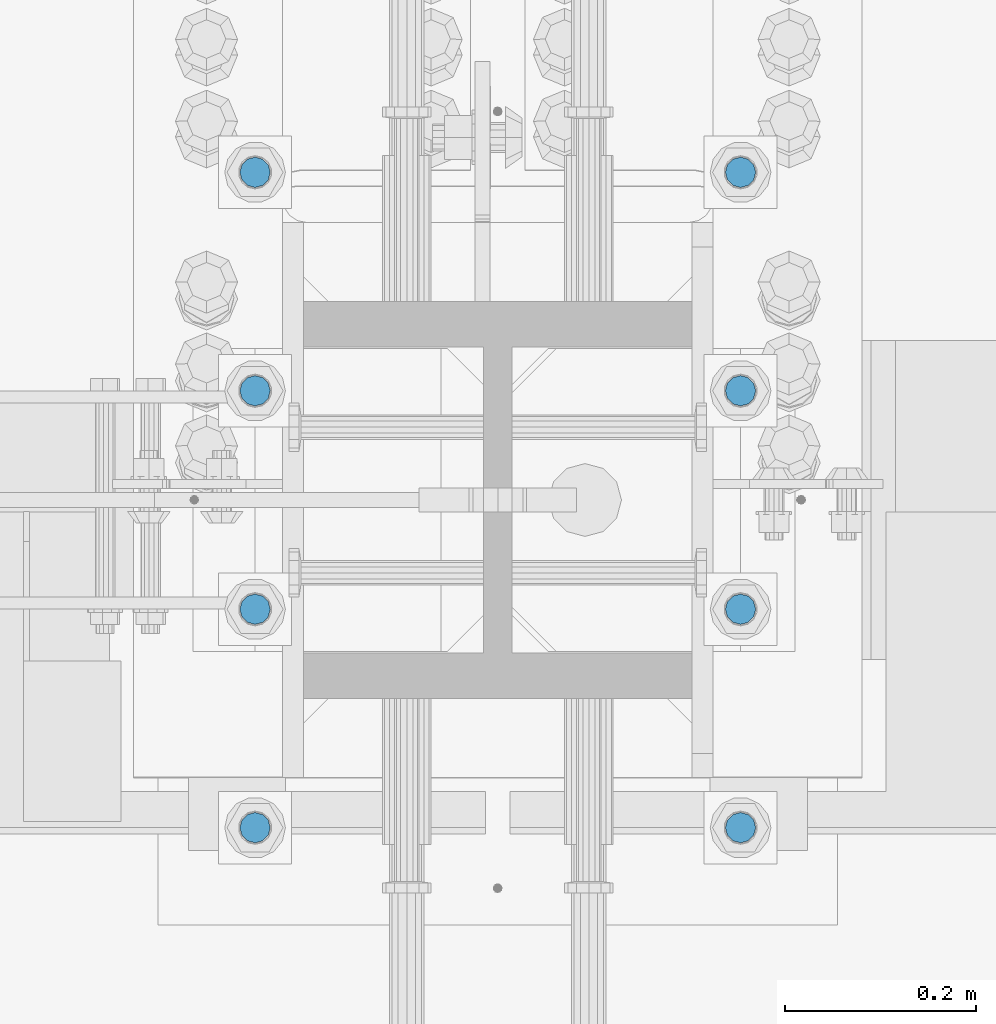
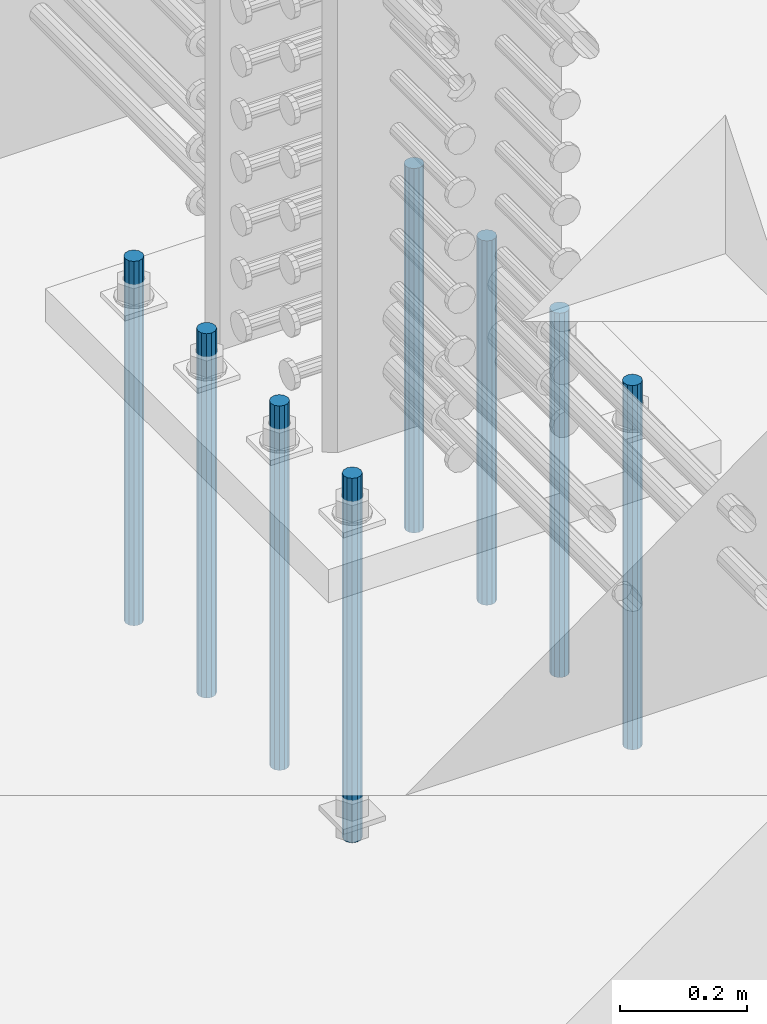
# One storey, part 937 of 1763: 8 columns, 1 element without a shape of its own.
"""IFC2X3 building model written with IfcOpenShell, lengths in millimetres."""

from ifc_helpers import new_model, si_unit, frame, origin_with_axes, place, context, subcontext, project, spatial, faceted_brep, material, type_object, element, aggregate, save


model = new_model("IFC2X3")

# Units and contexts
model_context = context("Model", 3, precision=1e-05, world=origin_with_axes())
body_context = subcontext(model_context, "Body", "Model", "MODEL_VIEW")
ifc_project = project(units=[si_unit("LENGTHUNIT", "METRE", prefix="MILLI"), si_unit("AREAUNIT", "SQUARE_METRE"), si_unit("VOLUMEUNIT", "CUBIC_METRE"), si_unit("MASSUNIT", "GRAM", prefix="KILO"), si_unit("TIMEUNIT", "SECOND"), si_unit("PLANEANGLEUNIT", "RADIAN"), si_unit("SOLIDANGLEUNIT", "STERADIAN"), si_unit("THERMODYNAMICTEMPERATUREUNIT", "DEGREE_CELSIUS"), si_unit("LUMINOUSINTENSITYUNIT", "LUMEN")], contexts=[model_context])

# Site, building, storey
site_placement = place(None, origin_with_axes())
site = spatial("IfcSite", under=ifc_project, at=site_placement, CompositionType="ELEMENT")
building_placement = place(site_placement, origin_with_axes())
building = spatial("IfcBuilding", under=site, at=building_placement, Name="Undefined", CompositionType="ELEMENT")
storey_placement = place(building_placement, origin_with_axes())
storey = spatial("IfcBuildingStorey", under=building, at=storey_placement, Name="Undefined", CompositionType="ELEMENT", Elevation=0.0)

# Assembly, columns
assembly_placement = place(storey_placement, origin_with_axes())
assembly = element("IfcElementAssembly", 1, at=assembly_placement, inside=storey, Name="TEMPLATE", AssemblyPlace="NOTDEFINED", PredefinedType="RIGID_FRAME")
ifc_material = material()
column_type = type_object("IfcColumnType", PredefinedType="NOTDEFINED")
column_1_placement = place(assembly_placement, frame((-24281.8372736984, -14058.9000000001, 4000.5), z_axis=(0.0, -1.0, 0.0), x_axis=(0.0, 0.0, -1.0)))
column_1 = element("IfcColumn", 2, at=column_1_placement, type_object=column_type, material=ifc_material, Name="ALL THREADED ROD", context=body_context, shape_type="Brep", body=[
    faceted_brep([(0.0, -15.875, 0.0), (0.0, -13.7481532850798, -7.9375), (698.499, -13.7481532850798, -7.9375), (698.499, -15.875, 0.0), (0.0, -7.9375, -13.748153285078), (698.499, -7.9375, -13.748153285078), (4.91792532185561e-12, 0.0, -15.875), (698.499, 0.0, -15.875), (0.0, 7.9375, -13.748153285078), (698.499, 7.9375, -13.748153285078), (0.0, 13.7481532850798, -7.9375), (698.499, 13.7481532850798, -7.9375), (0.0, 15.875, 0.0), (698.499, 15.875, 0.0), (0.0, 13.7481532850798, 7.9375), (698.499, 13.7481532850798, 7.9375), (0.0, 7.9375, 13.748153285078), (698.499, 7.9375, 13.748153285078), (-1.64518337079051e-12, 0.0, 15.875), (698.499, 0.0, 15.875), (0.0, -7.9375, 13.748153285078), (698.499, -7.9375, 13.748153285078), (0.0, -13.7481532850798, 7.9375), (698.499, -13.7481532850798, 7.9375)], [[[0, 1, 2, 3]], [[1, 4, 5, 2]], [[4, 6, 7, 5]], [[6, 8, 9, 7]], [[8, 10, 11, 9]], [[10, 12, 13, 11]], [[12, 14, 15, 13]], [[14, 16, 17, 15]], [[16, 18, 19, 17]], [[18, 20, 21, 19]], [[20, 22, 23, 21]], [[22, 0, 3, 23]], [[5, 7, 9, 11, 13, 15, 17, 19, 21, 23, 3, 2]], [[22, 20, 18, 16, 14, 12, 10, 8, 6, 4, 1, 0]]]),
])
column_2_placement = place(assembly_placement, frame((-23773.8372736984, -14058.9000000001, 4000.5), z_axis=(0.0, 1.0, 0.0), x_axis=(0.0, 0.0, -1.0)))
column_2 = element("IfcColumn", 3, at=column_2_placement, type_object=column_type, material=ifc_material, Name="ALL THREADED ROD", context=body_context, shape_type="Brep", body=[
    faceted_brep([(0.0, -15.875, 0.0), (0.0, -13.7481532850798, -7.9375), (698.499, -13.7481532850798, -7.9375), (698.499, -15.875, 0.0), (0.0, -7.9375, -13.748153285078), (698.499, -7.9375, -13.748153285078), (4.91792532185561e-12, 0.0, -15.875), (698.499, 0.0, -15.875), (0.0, 7.9375, -13.748153285078), (698.499, 7.9375, -13.748153285078), (0.0, 13.7481532850798, -7.9375), (698.499, 13.7481532850798, -7.9375), (0.0, 15.875, 0.0), (698.499, 15.875, 0.0), (0.0, 13.7481532850798, 7.9375), (698.499, 13.7481532850798, 7.9375), (0.0, 7.9375, 13.748153285078), (698.499, 7.9375, 13.748153285078), (-1.64518337079051e-12, 0.0, 15.875), (698.499, 0.0, 15.875), (0.0, -7.9375, 13.748153285078), (698.499, -7.9375, 13.748153285078), (0.0, -13.7481532850798, 7.9375), (698.499, -13.7481532850798, 7.9375)], [[[0, 1, 2, 3]], [[1, 4, 5, 2]], [[4, 6, 7, 5]], [[6, 8, 9, 7]], [[8, 10, 11, 9]], [[10, 12, 13, 11]], [[12, 14, 15, 13]], [[14, 16, 17, 15]], [[16, 18, 19, 17]], [[18, 20, 21, 19]], [[20, 22, 23, 21]], [[22, 0, 3, 23]], [[5, 7, 9, 11, 13, 15, 17, 19, 21, 23, 3, 2]], [[22, 20, 18, 16, 14, 12, 10, 8, 6, 4, 1, 0]]]),
])
column_3_placement = place(assembly_placement, frame((-24281.8372736984, -13830.3000000001, 4000.5), z_axis=(0.0, -1.0, 0.0), x_axis=(0.0, 0.0, -1.0)))
column_3 = element("IfcColumn", 4, at=column_3_placement, type_object=column_type, material=ifc_material, Name="ALL THREADED ROD", context=body_context, shape_type="Brep", body=[
    faceted_brep([(0.0, -15.875, 0.0), (0.0, -13.7481532850798, -7.9375), (698.499, -13.7481532850798, -7.9375), (698.499, -15.875, 0.0), (0.0, -7.9375, -13.748153285078), (698.499, -7.9375, -13.748153285078), (4.91792532185561e-12, 0.0, -15.875), (698.499, 0.0, -15.875), (0.0, 7.9375, -13.748153285078), (698.499, 7.9375, -13.748153285078), (0.0, 13.7481532850798, -7.9375), (698.499, 13.7481532850798, -7.9375), (0.0, 15.875, 0.0), (698.499, 15.875, 0.0), (0.0, 13.7481532850798, 7.9375), (698.499, 13.7481532850798, 7.9375), (0.0, 7.9375, 13.748153285078), (698.499, 7.9375, 13.748153285078), (-1.64518337079051e-12, 0.0, 15.875), (698.499, 0.0, 15.875), (0.0, -7.9375, 13.748153285078), (698.499, -7.9375, 13.748153285078), (0.0, -13.7481532850798, 7.9375), (698.499, -13.7481532850798, 7.9375)], [[[0, 1, 2, 3]], [[1, 4, 5, 2]], [[4, 6, 7, 5]], [[6, 8, 9, 7]], [[8, 10, 11, 9]], [[10, 12, 13, 11]], [[12, 14, 15, 13]], [[14, 16, 17, 15]], [[16, 18, 19, 17]], [[18, 20, 21, 19]], [[20, 22, 23, 21]], [[22, 0, 3, 23]], [[5, 7, 9, 11, 13, 15, 17, 19, 21, 23, 3, 2]], [[22, 20, 18, 16, 14, 12, 10, 8, 6, 4, 1, 0]]]),
])
column_4_placement = place(assembly_placement, frame((-23773.8372736984, -13830.3000000001, 4000.5), z_axis=(0.0, 1.0, 0.0), x_axis=(0.0, 0.0, -1.0)))
column_4 = element("IfcColumn", 5, at=column_4_placement, type_object=column_type, material=ifc_material, Name="ALL THREADED ROD", context=body_context, shape_type="Brep", body=[
    faceted_brep([(0.0, -15.875, 0.0), (0.0, -13.7481532850798, -7.9375), (698.499, -13.7481532850798, -7.9375), (698.499, -15.875, 0.0), (0.0, -7.9375, -13.748153285078), (698.499, -7.9375, -13.748153285078), (4.91792532185561e-12, 0.0, -15.875), (698.499, 0.0, -15.875), (0.0, 7.9375, -13.748153285078), (698.499, 7.9375, -13.748153285078), (0.0, 13.7481532850798, -7.9375), (698.499, 13.7481532850798, -7.9375), (0.0, 15.875, 0.0), (698.499, 15.875, 0.0), (0.0, 13.7481532850798, 7.9375), (698.499, 13.7481532850798, 7.9375), (0.0, 7.9375, 13.748153285078), (698.499, 7.9375, 13.748153285078), (-1.64518337079051e-12, 0.0, 15.875), (698.499, 0.0, 15.875), (0.0, -7.9375, 13.748153285078), (698.499, -7.9375, 13.748153285078), (0.0, -13.7481532850798, 7.9375), (698.499, -13.7481532850798, 7.9375)], [[[0, 1, 2, 3]], [[1, 4, 5, 2]], [[4, 6, 7, 5]], [[6, 8, 9, 7]], [[8, 10, 11, 9]], [[10, 12, 13, 11]], [[12, 14, 15, 13]], [[14, 16, 17, 15]], [[16, 18, 19, 17]], [[18, 20, 21, 19]], [[20, 22, 23, 21]], [[22, 0, 3, 23]], [[5, 7, 9, 11, 13, 15, 17, 19, 21, 23, 3, 2]], [[22, 20, 18, 16, 14, 12, 10, 8, 6, 4, 1, 0]]]),
])
column_5_placement = place(assembly_placement, frame((-24281.8372736984, -13601.7000000001, 4000.5), z_axis=(0.0, -1.0, 0.0), x_axis=(0.0, 0.0, -1.0)))
column_5 = element("IfcColumn", 6, at=column_5_placement, type_object=column_type, material=ifc_material, Name="ALL THREADED ROD", context=body_context, shape_type="Brep", body=[
    faceted_brep([(0.0, -15.875, 0.0), (0.0, -13.7481532850798, -7.9375), (698.499, -13.7481532850798, -7.9375), (698.499, -15.875, 0.0), (0.0, -7.9375, -13.748153285078), (698.499, -7.9375, -13.748153285078), (4.91792532185561e-12, 0.0, -15.875), (698.499, 0.0, -15.875), (0.0, 7.9375, -13.748153285078), (698.499, 7.9375, -13.748153285078), (0.0, 13.7481532850798, -7.9375), (698.499, 13.7481532850798, -7.9375), (0.0, 15.875, 0.0), (698.499, 15.875, 0.0), (0.0, 13.7481532850798, 7.9375), (698.499, 13.7481532850798, 7.9375), (0.0, 7.9375, 13.748153285078), (698.499, 7.9375, 13.748153285078), (-1.64518337079051e-12, 0.0, 15.875), (698.499, 0.0, 15.875), (0.0, -7.9375, 13.748153285078), (698.499, -7.9375, 13.748153285078), (0.0, -13.7481532850798, 7.9375), (698.499, -13.7481532850798, 7.9375)], [[[0, 1, 2, 3]], [[1, 4, 5, 2]], [[4, 6, 7, 5]], [[6, 8, 9, 7]], [[8, 10, 11, 9]], [[10, 12, 13, 11]], [[12, 14, 15, 13]], [[14, 16, 17, 15]], [[16, 18, 19, 17]], [[18, 20, 21, 19]], [[20, 22, 23, 21]], [[22, 0, 3, 23]], [[5, 7, 9, 11, 13, 15, 17, 19, 21, 23, 3, 2]], [[22, 20, 18, 16, 14, 12, 10, 8, 6, 4, 1, 0]]]),
])
column_6_placement = place(assembly_placement, frame((-23773.8372736984, -13601.7000000001, 4000.5), z_axis=(0.0, 1.0, 0.0), x_axis=(0.0, 0.0, -1.0)))
column_6 = element("IfcColumn", 7, at=column_6_placement, type_object=column_type, material=ifc_material, Name="ALL THREADED ROD", context=body_context, shape_type="Brep", body=[
    faceted_brep([(0.0, -15.875, 0.0), (0.0, -13.7481532850798, -7.9375), (698.499, -13.7481532850798, -7.9375), (698.499, -15.875, 0.0), (0.0, -7.9375, -13.748153285078), (698.499, -7.9375, -13.748153285078), (4.91792532185561e-12, 0.0, -15.875), (698.499, 0.0, -15.875), (0.0, 7.9375, -13.748153285078), (698.499, 7.9375, -13.748153285078), (0.0, 13.7481532850798, -7.9375), (698.499, 13.7481532850798, -7.9375), (0.0, 15.875, 0.0), (698.499, 15.875, 0.0), (0.0, 13.7481532850798, 7.9375), (698.499, 13.7481532850798, 7.9375), (0.0, 7.9375, 13.748153285078), (698.499, 7.9375, 13.748153285078), (-1.64518337079051e-12, 0.0, 15.875), (698.499, 0.0, 15.875), (0.0, -7.9375, 13.748153285078), (698.499, -7.9375, 13.748153285078), (0.0, -13.7481532850798, 7.9375), (698.499, -13.7481532850798, 7.9375)], [[[0, 1, 2, 3]], [[1, 4, 5, 2]], [[4, 6, 7, 5]], [[6, 8, 9, 7]], [[8, 10, 11, 9]], [[10, 12, 13, 11]], [[12, 14, 15, 13]], [[14, 16, 17, 15]], [[16, 18, 19, 17]], [[18, 20, 21, 19]], [[20, 22, 23, 21]], [[22, 0, 3, 23]], [[5, 7, 9, 11, 13, 15, 17, 19, 21, 23, 3, 2]], [[22, 20, 18, 16, 14, 12, 10, 8, 6, 4, 1, 0]]]),
])
column_7_placement = place(assembly_placement, frame((-24281.8372736984, -13373.1000000001, 4000.5), z_axis=(0.0, -1.0, 0.0), x_axis=(0.0, 0.0, -1.0)))
column_7 = element("IfcColumn", 8, at=column_7_placement, type_object=column_type, material=ifc_material, Name="ALL THREADED ROD", context=body_context, shape_type="Brep", body=[
    faceted_brep([(0.0, -15.875, 0.0), (0.0, -13.7481532850798, -7.9375), (698.499, -13.7481532850798, -7.9375), (698.499, -15.875, 0.0), (0.0, -7.9375, -13.748153285078), (698.499, -7.9375, -13.748153285078), (4.91792532185561e-12, 0.0, -15.875), (698.499, 0.0, -15.875), (0.0, 7.9375, -13.748153285078), (698.499, 7.9375, -13.748153285078), (0.0, 13.7481532850798, -7.9375), (698.499, 13.7481532850798, -7.9375), (0.0, 15.875, 0.0), (698.499, 15.875, 0.0), (0.0, 13.7481532850798, 7.9375), (698.499, 13.7481532850798, 7.9375), (0.0, 7.9375, 13.748153285078), (698.499, 7.9375, 13.748153285078), (-1.64518337079051e-12, 0.0, 15.875), (698.499, 0.0, 15.875), (0.0, -7.9375, 13.748153285078), (698.499, -7.9375, 13.748153285078), (0.0, -13.7481532850798, 7.9375), (698.499, -13.7481532850798, 7.9375)], [[[0, 1, 2, 3]], [[1, 4, 5, 2]], [[4, 6, 7, 5]], [[6, 8, 9, 7]], [[8, 10, 11, 9]], [[10, 12, 13, 11]], [[12, 14, 15, 13]], [[14, 16, 17, 15]], [[16, 18, 19, 17]], [[18, 20, 21, 19]], [[20, 22, 23, 21]], [[22, 0, 3, 23]], [[5, 7, 9, 11, 13, 15, 17, 19, 21, 23, 3, 2]], [[22, 20, 18, 16, 14, 12, 10, 8, 6, 4, 1, 0]]]),
])
column_8_placement = place(assembly_placement, frame((-23773.8372736984, -13373.1000000001, 4000.5), z_axis=(0.0, 1.0, 0.0), x_axis=(0.0, 0.0, -1.0)))
column_8 = element("IfcColumn", 9, at=column_8_placement, type_object=column_type, material=ifc_material, Name="ALL THREADED ROD", context=body_context, shape_type="Brep", body=[
    faceted_brep([(0.0, -15.875, 0.0), (0.0, -13.7481532850798, -7.9375), (698.499, -13.7481532850798, -7.9375), (698.499, -15.875, 0.0), (0.0, -7.9375, -13.748153285078), (698.499, -7.9375, -13.748153285078), (4.91792532185561e-12, 0.0, -15.875), (698.499, 0.0, -15.875), (0.0, 7.9375, -13.748153285078), (698.499, 7.9375, -13.748153285078), (0.0, 13.7481532850798, -7.9375), (698.499, 13.7481532850798, -7.9375), (0.0, 15.875, 0.0), (698.499, 15.875, 0.0), (0.0, 13.7481532850798, 7.9375), (698.499, 13.7481532850798, 7.9375), (0.0, 7.9375, 13.748153285078), (698.499, 7.9375, 13.748153285078), (-1.64518337079051e-12, 0.0, 15.875), (698.499, 0.0, 15.875), (0.0, -7.9375, 13.748153285078), (698.499, -7.9375, 13.748153285078), (0.0, -13.7481532850798, 7.9375), (698.499, -13.7481532850798, 7.9375)], [[[0, 1, 2, 3]], [[1, 4, 5, 2]], [[4, 6, 7, 5]], [[6, 8, 9, 7]], [[8, 10, 11, 9]], [[10, 12, 13, 11]], [[12, 14, 15, 13]], [[14, 16, 17, 15]], [[16, 18, 19, 17]], [[18, 20, 21, 19]], [[20, 22, 23, 21]], [[22, 0, 3, 23]], [[5, 7, 9, 11, 13, 15, 17, 19, 21, 23, 3, 2]], [[22, 20, 18, 16, 14, 12, 10, 8, 6, 4, 1, 0]]]),
])
aggregate(assembly, [column_1, column_2, column_3, column_4, column_5, column_6, column_7, column_8])

save(model, "model.ifc")
